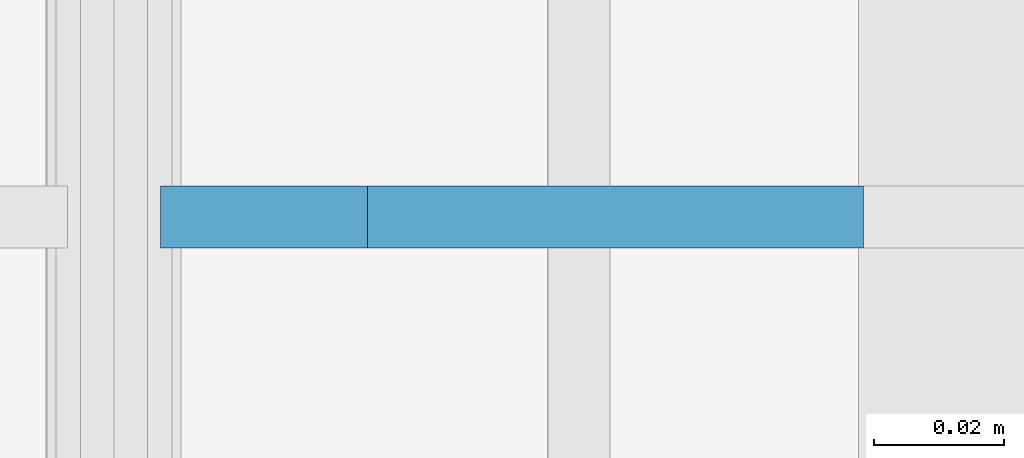
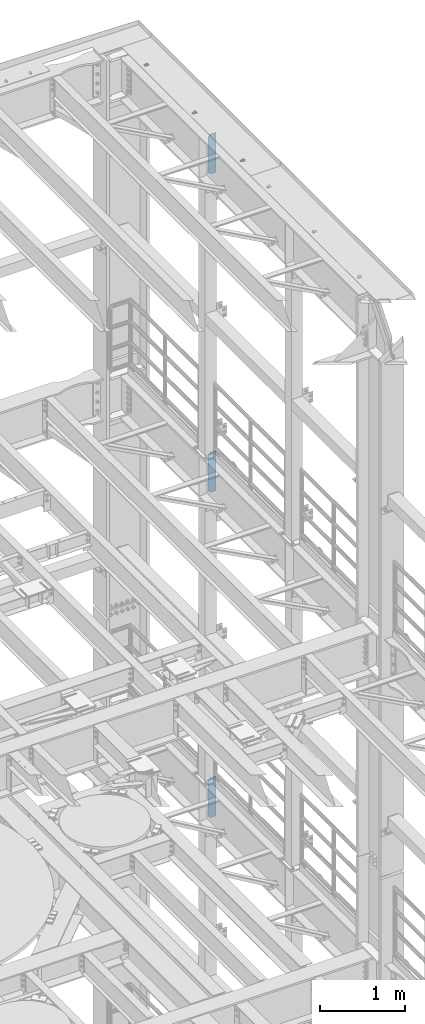
# One storey, part 1823 of 1876: 3 plates, 3 elements without a shape of their own.
"""IFC2X3 building model written with IfcOpenShell, lengths in millimetres."""

from ifc_helpers import new_model, si_unit, frame, origin_with_axes, place, context, subcontext, project, spatial, faceted_brep, material, type_object, element, aggregate, save


model = new_model("IFC2X3")

# Units and contexts
model_context = context("Model", 3, precision=1e-05, world=origin_with_axes())
body_context = subcontext(model_context, "Body", "Model", "MODEL_VIEW")
ifc_project = project(units=[si_unit("LENGTHUNIT", "METRE", prefix="MILLI"), si_unit("AREAUNIT", "SQUARE_METRE"), si_unit("VOLUMEUNIT", "CUBIC_METRE"), si_unit("MASSUNIT", "GRAM", prefix="KILO"), si_unit("TIMEUNIT", "SECOND"), si_unit("PLANEANGLEUNIT", "RADIAN"), si_unit("SOLIDANGLEUNIT", "STERADIAN"), si_unit("THERMODYNAMICTEMPERATUREUNIT", "DEGREE_CELSIUS"), si_unit("LUMINOUSINTENSITYUNIT", "LUMEN")], contexts=[model_context])

# Site, building, storey
site_placement = place(None, origin_with_axes())
site = spatial("IfcSite", under=ifc_project, at=site_placement, CompositionType="ELEMENT")
building_placement = place(site_placement, origin_with_axes())
building = spatial("IfcBuilding", under=site, at=building_placement, Name="Undefined", CompositionType="ELEMENT")
storey_placement = place(building_placement, origin_with_axes())
storey = spatial("IfcBuildingStorey", under=building, at=storey_placement, Name="Undefined", CompositionType="ELEMENT", Elevation=0.0)

# Assembly, plate
assembly_1_placement = place(storey_placement, origin_with_axes())
assembly_1 = element("IfcElementAssembly", 1, at=assembly_1_placement, inside=storey, Name="BEAM", AssemblyPlace="NOTDEFINED", PredefinedType="RIGID_FRAME")
ifc_material = material(Name="STEEL/A36")
plate_type = type_object("IfcPlateType", PredefinedType="NOTDEFINED")
plate_1_placement = place(assembly_1_placement, frame((7735.09375, 11684.0, 21958.3), z_axis=(0.0, 0.0, 1.0), x_axis=(-1.0, 0.0, 0.0)))
plate_1 = element("IfcPlate", 2, at=plate_1_placement, type_object=plate_type, material=ifc_material, Name="PLATE", context=body_context, shape_type="Brep", body=[
    faceted_brep([(0.0, -4.76249999999982, 0.0), (0.0, -4.76249999999982, 571.5), (0.0, 4.76249999999982, 571.5), (0.0, 4.76249999999982, 0.0), (76.1999969482422, -4.76249999999982, 571.5), (76.1999969482422, 4.76249999999982, 571.5), (107.949996948242, -4.76249999999982, 539.75), (107.949996948242, 4.76249999999982, 539.75), (107.949996948242, -4.76249999999982, 31.75), (107.949996948242, 4.76249999999982, 31.75), (76.1999969482422, -4.76250000000073, 0.0), (76.1999969482422, 4.76250000000073, 0.0)], [[[0, 1, 2, 3]], [[1, 4, 5, 2]], [[4, 6, 7, 5]], [[6, 8, 9, 7]], [[8, 10, 11, 9]], [[10, 0, 3, 11]], [[5, 7, 9, 11, 3, 2]], [[10, 8, 6, 4, 1, 0]]]),
])
aggregate(assembly_1, [plate_1])

assembly_2_placement = place(storey_placement, origin_with_axes())
assembly_2 = element("IfcElementAssembly", 3, at=assembly_2_placement, inside=storey, Name="BEAM", AssemblyPlace="NOTDEFINED", PredefinedType="RIGID_FRAME")
plate_2_placement = place(assembly_2_placement, frame((7735.09375, 11684.0, 17386.3), z_axis=(0.0, 0.0, 1.0), x_axis=(-1.0, 0.0, 0.0)))
plate_2 = element("IfcPlate", 4, at=plate_2_placement, type_object=plate_type, material=ifc_material, Name="PLATE", context=body_context, shape_type="Brep", body=[
    faceted_brep([(0.0, -4.76249999999982, 0.0), (0.0, -4.76249999999982, 571.5), (0.0, 4.76249999999982, 571.5), (0.0, 4.76249999999982, 0.0), (76.1999969482422, -4.76249999999982, 571.5), (76.1999969482422, 4.76249999999982, 571.5), (107.949996948242, -4.76249999999982, 539.75), (107.949996948242, 4.76249999999982, 539.75), (107.949996948242, -4.76249999999982, 31.75), (107.949996948242, 4.76249999999982, 31.75), (76.1999969482422, -4.76250000000073, 0.0), (76.1999969482422, 4.76250000000073, 0.0)], [[[0, 1, 2, 3]], [[1, 4, 5, 2]], [[4, 6, 7, 5]], [[6, 8, 9, 7]], [[8, 10, 11, 9]], [[10, 0, 3, 11]], [[5, 7, 9, 11, 3, 2]], [[10, 8, 6, 4, 1, 0]]]),
])
aggregate(assembly_2, [plate_2])

assembly_3_placement = place(storey_placement, origin_with_axes())
assembly_3 = element("IfcElementAssembly", 5, at=assembly_3_placement, inside=storey, Name="BEAM", AssemblyPlace="NOTDEFINED", PredefinedType="RIGID_FRAME")
plate_3_placement = place(assembly_3_placement, frame((7735.09375, 11684.0, 12712.7), z_axis=(0.0, 0.0, 1.0), x_axis=(-1.0, 0.0, 0.0)))
plate_3 = element("IfcPlate", 6, at=plate_3_placement, type_object=plate_type, material=ifc_material, Name="PLATE", context=body_context, shape_type="Brep", body=[
    faceted_brep([(0.0, -4.76249999999982, 0.0), (0.0, -4.76249999999982, 571.5), (0.0, 4.76249999999982, 571.5), (0.0, 4.76249999999982, 0.0), (76.1999969482422, -4.76249999999982, 571.5), (76.1999969482422, 4.76249999999982, 571.5), (107.949996948242, -4.76249999999982, 539.75), (107.949996948242, 4.76249999999982, 539.75), (107.949996948242, -4.76249999999982, 31.75), (107.949996948242, 4.76249999999982, 31.75), (76.1999969482422, -4.76250000000073, 0.0), (76.1999969482422, 4.76250000000073, 0.0)], [[[0, 1, 2, 3]], [[1, 4, 5, 2]], [[4, 6, 7, 5]], [[6, 8, 9, 7]], [[8, 10, 11, 9]], [[10, 0, 3, 11]], [[5, 7, 9, 11, 3, 2]], [[10, 8, 6, 4, 1, 0]]]),
])
aggregate(assembly_3, [plate_3])

save(model, "model.ifc")
